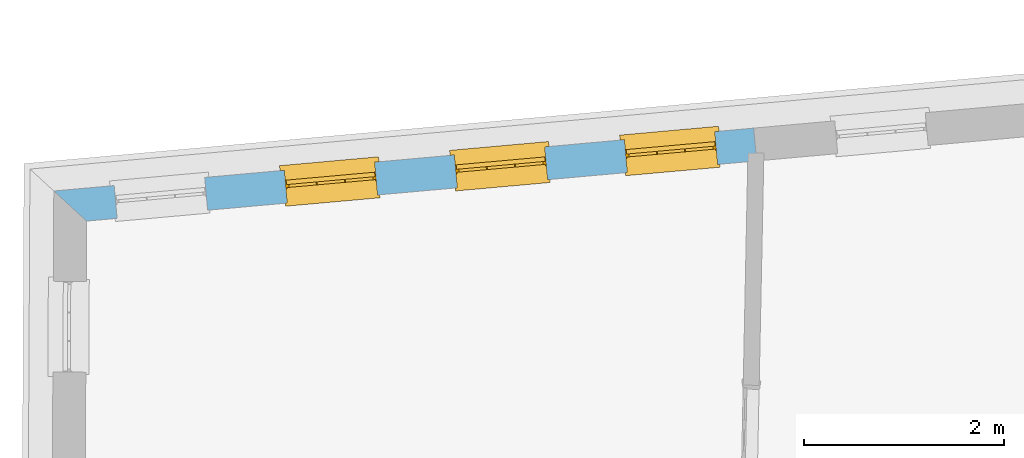
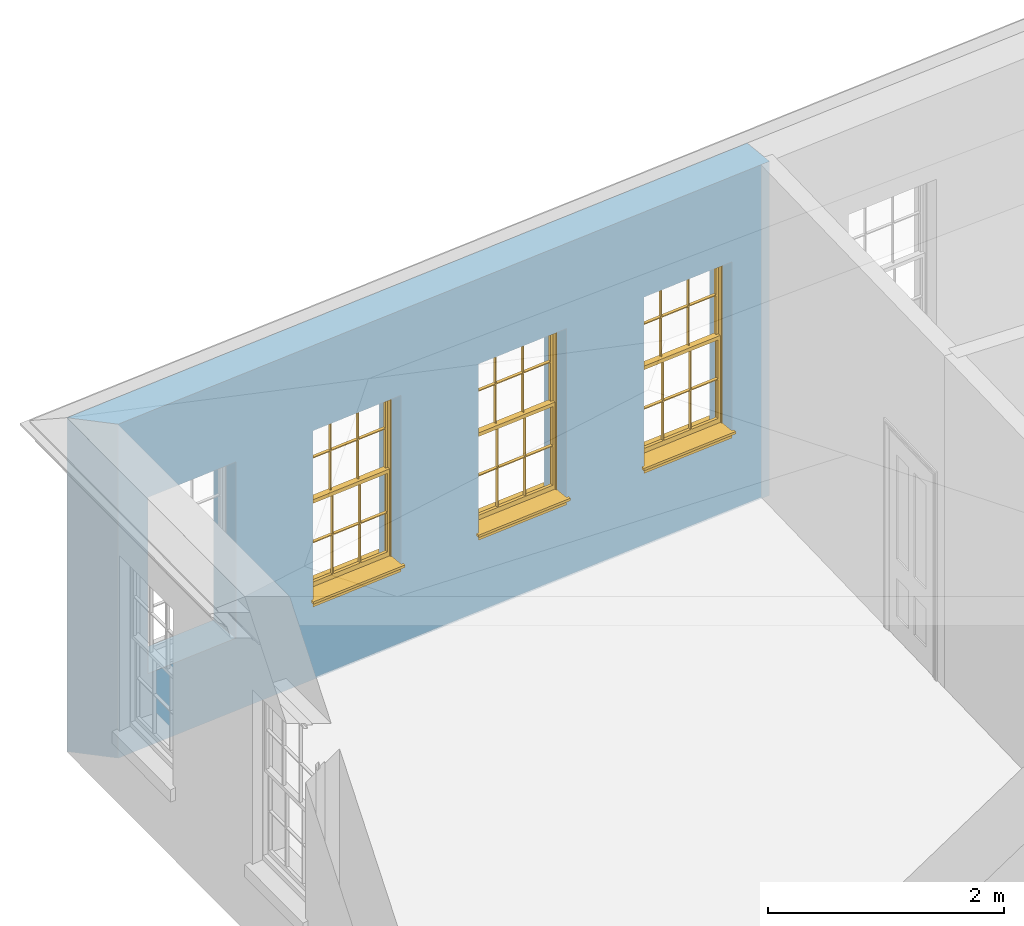
# One storey, part 5 of 14: 3 windows, 4 openings, plus 1 element that does not belong to this part.
"""IFC2X3 building model written with IfcOpenShell, lengths in metres."""

import ifcopenshell
import ifcopenshell.guid

model = None  # the IFC model being written
_history = None  # IfcOwnerHistory: only IFC2X3 demands one
_inside = {}  # id of a spatial element -> (the spatial element, [elements in it])
_under = {}  # id of a project, library or spatial element -> (it, [spatial elements below it])
_declared = {}  # id of a project -> (the project, [libraries it declares])
_typed = {}  # id of a type object -> (the type object, [elements of that type])
_made_of = {}  # id of a material, layer set ... -> (it, [elements and type objects made of it])


def new_model(schema):
    """Start an empty IFC model of exactly this schema.

    Asked for "IFC4X3", IfcOpenShell would pick the latest addendum, in which some entities
    have other attributes; the version numbers below select the first issue.
    IFC2X3 requires an IfcOwnerHistory on every rooted entity: one is made here for all.
    """
    global model, _history
    if schema == "IFC4X3":
        model = ifcopenshell.file(schema_version=(4, 3, 0, 0))
    else:
        model = ifcopenshell.file(schema=schema)
    _inside.clear()
    _under.clear()
    _declared.clear()
    _typed.clear()
    _made_of.clear()
    _history = None
    if model.schema == "IFC2X3":
        org = make("IfcOrganization", Name="unknown")
        user = make(
            "IfcPersonAndOrganization",
            ThePerson=make("IfcPerson", FamilyName="unknown"),
            TheOrganization=org,
        )
        app = make(
            "IfcApplication",
            ApplicationDeveloper=org,
            Version="unknown",
            ApplicationFullName="unknown",
            ApplicationIdentifier="unknown",
        )
        _history = make(
            "IfcOwnerHistory",
            OwningUser=user,
            OwningApplication=app,
            ChangeAction="ADDED",
            CreationDate=0,
        )
    return model


def make(cls, **values):
    """One entity of the class cls with the attributes given. An attribute that is None is left unset."""
    return model.create_entity(
        cls, **{name: value for name, value in values.items() if value is not None}
    )


def rooted(cls, **values):
    """An entity with a GlobalId (a new one), such as an element, a storey or a relation."""
    return make(cls, GlobalId=ifcopenshell.guid.new(), OwnerHistory=_history, **values)


def si_unit(unit_type, name, prefix=None):
    """IfcSIUnit, for example si_unit("LENGTHUNIT", "METRE", prefix="MILLI")."""
    return make("IfcSIUnit", UnitType=unit_type, Prefix=prefix, Name=name)


def assignment(units):
    """IfcUnitAssignment: the units of a project."""
    return None if units is None else make("IfcUnitAssignment", Units=units)


def point(xyz):
    """IfcCartesianPoint."""
    return None if xyz is None else make("IfcCartesianPoint", Coordinates=xyz)


def direction(xyz):
    """IfcDirection."""
    return None if xyz is None else make("IfcDirection", DirectionRatios=xyz)


def frame(location, z_axis=None, x_axis=None):
    """IfcAxis2Placement3D, a coordinate frame: its origin and axes. An axis left out is left unset."""
    return make(
        "IfcAxis2Placement3D",
        Location=point(location),
        Axis=direction(z_axis),
        RefDirection=direction(x_axis),
    )


def origin():
    """The frame at (0, 0, 0) with its axes left unset."""
    return frame((0.0, 0.0, 0.0))


def place(relative_to, where):
    """IfcLocalPlacement: puts the frame where relative to a parent placement (None: the world)."""
    return make(
        "IfcLocalPlacement", PlacementRelTo=relative_to, RelativePlacement=where
    )


def context(
    kind, dimensions, precision=None, world=None, true_north=None, identifier=None
):
    """IfcGeometricRepresentationContext, for example the 3D "Model" context."""
    return make(
        "IfcGeometricRepresentationContext",
        ContextIdentifier=identifier,
        ContextType=kind,
        CoordinateSpaceDimension=dimensions,
        Precision=precision,
        WorldCoordinateSystem=world,
        TrueNorth=true_north,
    )


def subcontext(parent, identifier, kind, view, scale=None):
    """IfcGeometricRepresentationSubContext, for example "Body" below "Model"."""
    return make(
        "IfcGeometricRepresentationSubContext",
        ContextIdentifier=identifier,
        ContextType=kind,
        ParentContext=parent,
        TargetScale=scale,
        TargetView=view,
    )


def project(units=None, contexts=None):
    """IfcProject with its units and contexts."""
    return rooted(
        "IfcProject",
        Name="project",
        RepresentationContexts=contexts,
        UnitsInContext=assignment(units),
    )


def spatial(cls, under=None, at=None, **own):
    """A site, building, storey or space (cls), placed at a placement, below another one or the project."""
    s = rooted(cls, ObjectPlacement=at, **own)
    if under is not None:
        _under.setdefault(under.id(), (under, []))[1].append(s)
    return s


def polyline(points):
    """IfcPolyline through the points."""
    return make("IfcPolyline", Points=[point(p) for p in points])


def outline(outer, holes=None, kind="AREA"):
    """IfcArbitraryClosedProfileDef: a profile drawn as a closed curve; with holes, ...WithVoids."""
    if holes is None:
        return make("IfcArbitraryClosedProfileDef", ProfileType=kind, OuterCurve=outer)
    return make(
        "IfcArbitraryProfileDefWithVoids",
        ProfileType=kind,
        OuterCurve=outer,
        InnerCurves=holes,
    )


def extrude(swept, where, along, depth):
    """IfcExtrudedAreaSolid: the profile swept, set in the frame where, extruded along a direction by depth."""
    return make(
        "IfcExtrudedAreaSolid",
        SweptArea=swept,
        Position=where,
        ExtrudedDirection=direction(along),
        Depth=depth,
    )


def faces_of(points, faces, orient=None, outer=None):
    """IfcFace entities. A face is a list of loops; a loop is a list of indices into points, from 0.

    orient and outer hold one flag for each loop. By default every Orientation is true, the
    first loop of a face is its IfcFaceOuterBound and the others are IfcFaceBound.
    """
    made = []
    for i, loops in enumerate(faces):
        bounds = []
        for j, loop in enumerate(loops):
            is_outer = j == 0 if outer is None else outer[i][j]
            bounds.append(
                make(
                    "IfcFaceOuterBound" if is_outer else "IfcFaceBound",
                    Bound=make("IfcPolyLoop", Polygon=[points[k] for k in loop]),
                    Orientation=True if orient is None else orient[i][j],
                )
            )
        made.append(make("IfcFace", Bounds=bounds))
    return made


def faceted_brep(points, faces, orient=None, outer=None, voids=None):
    """IfcFacetedBrep: a solid bounded by flat faces; with voids (closed shells), ...WithVoids."""
    shared = [point(p) for p in points]
    hull = make("IfcClosedShell", CfsFaces=faces_of(shared, faces, orient, outer))
    if voids is None:
        return make("IfcFacetedBrep", Outer=hull)
    return make(
        "IfcFacetedBrepWithVoids",
        Outer=hull,
        Voids=[
            make(cls, CfsFaces=faces_of(shared, fs, o, b)) for cls, fs, o, b in voids
        ],
    )


def shape(context_of_items, identifier, shape_type, items):
    """IfcShapeRepresentation: the items that make up one representation, for example the "Body"."""
    return make(
        "IfcShapeRepresentation",
        ContextOfItems=context_of_items,
        RepresentationIdentifier=identifier,
        RepresentationType=shape_type,
        Items=items,
    )


def material(Name=None, Category=None):
    """IfcMaterial."""
    return make("IfcMaterial", Name=Name, Category=Category)


def layer(
    of_material, thickness, ventilated=None, Name=None, Category=None, Priority=None
):
    """IfcMaterialLayer: one layer of a wall or slab, of a material (None: an air gap)."""
    return make(
        "IfcMaterialLayer",
        Material=of_material,
        LayerThickness=thickness,
        IsVentilated=ventilated,
        Name=Name,
        Category=Category,
        Priority=Priority,
    )


def layer_set(layers, Name=None):
    """IfcMaterialLayerSet."""
    return make("IfcMaterialLayerSet", MaterialLayers=layers, LayerSetName=Name)


def layer_usage(for_layer_set, set_direction, sense, offset, extent=None):
    """IfcMaterialLayerSetUsage: how a layer set lies in its element."""
    return make(
        "IfcMaterialLayerSetUsage",
        ForLayerSet=for_layer_set,
        LayerSetDirection=set_direction,
        DirectionSense=sense,
        OffsetFromReferenceLine=offset,
        ReferenceExtent=extent,
    )


def made_of(thing, what):
    """Note that an element or type object is made of a material, layer set ...; save() writes the relation."""
    if what is not None:
        _made_of.setdefault(what.id(), (what, []))[1].append(thing)
    return thing


def element(
    cls,
    number,
    at=None,
    inside=None,
    cuts=None,
    type_object=None,
    material=None,
    context=None,
    identifier="Body",
    shape_type=None,
    held_by="IfcProductDefinitionShape",
    body=None,
    shapes=None,
    **own,
):
    """One element of the class cls, such as IfcWall. Its Tag is "e" and its number.

    at: its placement. inside: the storey or other place that contains it. cuts: it is an
    opening in that element (IfcRelVoidsElement). A single representation is given by context,
    identifier, shape_type and body (its items); several are given by shapes. held_by: the class
    of the entity that holds the representations. save() writes the other relations.
    """
    e = rooted(cls, Tag="e%d" % number, ObjectPlacement=at, **own)
    if body is not None:
        shapes = [shape(context, identifier, shape_type, body)]
    if shapes is not None:
        e.Representation = make(held_by, Representations=shapes)
    if inside is not None:
        _inside.setdefault(inside.id(), (inside, []))[1].append(e)
    if cuts is not None:
        rooted(
            "IfcRelVoidsElement", RelatingBuildingElement=cuts, RelatedOpeningElement=e
        )
    if type_object is not None:
        _typed.setdefault(type_object.id(), (type_object, []))[1].append(e)
    return made_of(e, material)


def fill(opening, filler):
    """IfcRelFillsElement: the door or window that sits in an opening."""
    return rooted(
        "IfcRelFillsElement",
        RelatingOpeningElement=opening,
        RelatedBuildingElement=filler,
    )


def aggregate(whole, parts):
    """IfcRelAggregates: a whole, such as a stair, and the parts it consists of."""
    return rooted("IfcRelAggregates", RelatingObject=whole, RelatedObjects=parts)


def save(model, path):
    """Write the relations noted so far, then the file.

    IfcRelAggregates (storeys below a building ...), IfcRelContainedInSpatialStructure (elements
    in a storey), IfcRelDefinesByType, IfcRelAssociatesMaterial and IfcRelDeclares: one each for
    every whole, place, type object, material and project.
    """
    for whole, parts in _under.values():
        aggregate(whole, parts)
    for where, things in _inside.values():
        rooted(
            "IfcRelContainedInSpatialStructure",
            RelatedElements=things,
            RelatingStructure=where,
        )
    for kind, things in _typed.values():
        rooted("IfcRelDefinesByType", RelatedObjects=things, RelatingType=kind)
    for what, things in _made_of.values():
        rooted("IfcRelAssociatesMaterial", RelatedObjects=things, RelatingMaterial=what)
    for by, libraries in _declared.values():
        rooted("IfcRelDeclares", RelatingContext=by, RelatedDefinitions=libraries)
    model.write(path)


model = new_model("IFC2X3")

# Units and contexts
model_context = context("Model", 3, world=origin())
body_context = subcontext(model_context, "Body", "Model", "MODEL_VIEW")
ifc_project = project(units=[si_unit("PLANEANGLEUNIT", "RADIAN"), si_unit("MASSUNIT", "GRAM", prefix="KILO"), si_unit("FORCEUNIT", "NEWTON", prefix="KILO"), si_unit("LENGTHUNIT", "METRE")], contexts=[model_context])

# Site, building, storey
site_placement = place(None, origin())
site = spatial("IfcSite", under=ifc_project, at=site_placement, CompositionType="ELEMENT")
building_placement = place(None, origin())
building = spatial("IfcBuilding", under=site, at=building_placement, Name="Building plot-17", CompositionType="ELEMENT")
storey_placement = place(None, frame((0.0, 0.0, 6.15)))
storey = spatial("IfcBuildingStorey", under=building, at=storey_placement, Name="Floor 1", CompositionType="ELEMENT", Elevation=6.15)

# Wall, openings, windows
ifc_material = material(Name="Masonry")
ifc_layer = layer(ifc_material, 0.33, ventilated=False)
ifc_layer_set = layer_set([ifc_layer], Name="My Wall")
ifc_layer_usage = layer_usage(ifc_layer_set, "AXIS2", "NEGATIVE", 0.08)
wall_placement = place(storey_placement, origin())
wall = element("IfcWallStandardCase", 1, at=wall_placement, inside=storey, material=ifc_layer_usage, Name="exterior", context=body_context, shape_type="SweptSolid", body=[
    extrude(outline(polyline([(77.4514973462638, 26.0607374425634), (77.4219746484992, 26.3894141991445), (70.4115738095909, 25.7597197013384), (70.7400454135505, 25.4578954009408), (77.4514973462638, 26.0607374425634)])), origin(), (0.0, 0.0, 1.0), 3.45),
])
opening_1_placement = place(storey_placement, frame((0.0, 0.0, 0.75)))
opening_1 = element("IfcOpeningElement", 2, at=opening_1_placement, cuts=wall, Name="Opening", ObjectType="Opening", context=body_context, shape_type="SweptSolid", body=[
    extrude(outline(polyline([(77.0323071544384, 26.354413136777), (76.1259560984116, 26.273002061123), (76.1554787961762, 25.9443253045419), (77.061829852203, 26.0257363801958), (77.0323071544384, 26.354413136777)])), origin(), (0.0, 0.0, 1.0), 1.82),
])
opening_2_placement = place(storey_placement, frame((0.0, 0.0, 0.75)))
opening_2 = element("IfcOpeningElement", 3, at=opening_2_placement, cuts=wall, Name="Opening", ObjectType="Opening", context=body_context, shape_type="SweptSolid", body=[
    extrude(outline(polyline([(75.3291639612452, 26.201431884724), (74.4228129052184, 26.12002080907), (74.452335602983, 25.7913440524889), (75.3586866590098, 25.8727551281428), (75.3291639612452, 26.201431884724)])), origin(), (0.0, 0.0, 1.0), 1.82),
])
opening_3_placement = place(storey_placement, frame((0.0, 0.0, 0.75)))
opening_3 = element("IfcOpeningElement", 4, at=opening_3_placement, cuts=wall, Name="Opening", ObjectType="Opening", context=body_context, shape_type="SweptSolid", body=[
    extrude(outline(polyline([(73.626020768052, 26.0484506326709), (72.7196697120252, 25.967039557017), (72.7491924097898, 25.6383628004358), (73.6555434658166, 25.7197738760898), (73.626020768052, 26.0484506326709)])), origin(), (0.0, 0.0, 1.0), 1.82),
])
opening_4_placement = place(storey_placement, frame((0.0, 0.0, 0.75)))
element("IfcOpeningElement", 5, at=opening_4_placement, cuts=wall, Name="Opening", ObjectType="Opening", context=body_context, shape_type="SweptSolid", body=[
    extrude(outline(polyline([(71.9228775748588, 25.8954693806179), (71.016526518832, 25.814058304964), (71.0460492165967, 25.4853815483828), (71.9524002726234, 25.5667926240368), (71.9228775748588, 25.8954693806179)])), origin(), (0.0, 0.0, 1.0), 1.82),
])
window_1_placement = place(storey_placement, frame((77.0546728345631, 26.1054155939125, 0.75), z_axis=(0.0, 0.0, 1.0), x_axis=(-0.906351056026793, -0.0814110756539463, 0.0)))
window_1 = element("IfcWindow", 6, at=window_1_placement, inside=storey, Name="bedroom outside window", OverallHeight=1.82, OverallWidth=0.91, context=body_context, shape_type="Brep", held_by="IfcProductRepresentation", body=[
    faceted_brep([(0.033125, -0.105, 0.975209), (0.01, -0.105, 0.975209), (0.033125, -0.105, 1.376042), (0.876875, -0.105, 0.975209), (0.876875, -0.105, 1.376042), (0.9, -0.105, 0.975209), (0.876875, -0.105, 1.386042), (0.876875, -0.105, 1.786875), (0.9, -0.105, 1.81), (0.033125, -0.105, 1.786875), (0.033125, -0.105, 1.386042), (0.01, -0.105, 1.81), (0.876875, -0.135, 1.376042), (0.876875, -0.135, 0.975209), (0.9, -0.135, 0.937083), (0.033125, -0.135, 1.786875), (0.01, -0.135, 1.81), (0.033125, -0.135, 1.386042), (0.01, -0.135, 0.937083), (0.033125, -0.135, 0.975209), (0.033125, -0.135, 1.376042), (0.876875, -0.135, 1.786875), (0.876875, -0.135, 1.386042), (0.9, -0.135, 1.81), (0.033125, -0.105, 0.937083), (0.01, -0.105, 0.937083), (0.033125, -0.105, 0.53625), (0.876875, -0.105, 0.937083), (0.876875, -0.105, 0.53625), (0.9, -0.105, 0.937083), (0.876875, -0.105, 0.52625), (0.876875, -0.105, 0.125417), (0.9, -0.105, 0.077167), (0.033125, -0.105, 0.125417), (0.033125, -0.105, 0.52625), (0.01, -0.105, 0.077167), (-0.0425, -0.25, 0.01), (-0.0425, -0.3, 0.001667), (0.0, -0.25, 0.01), (0.9525, -0.25, 0.01), (0.91, -0.25, 0.01), (0.9525, -0.3, 0.001667), (-0.02, 0.08, 0.077167), (0.0, 0.08, 0.077167), (-0.02, 0.11, 0.077167), (0.0, -0.06, 0.077167), (0.01, -0.06, 0.077167), (0.91, -0.06, 0.077167), (0.91, 0.08, 0.077167), (0.9, -0.06, 0.077167), (0.93, 0.08, 0.077167), (0.93, 0.11, 0.077167), (0.01, -0.075, 0.975209), (0.9, -0.075, 0.975209), (0.876875, -0.075, 0.125417), (0.876875, -0.075, 0.52625), (0.9, -0.075, 0.077167), (0.876875, -0.075, 0.53625), (0.876875, -0.075, 0.937083), (0.033125, -0.075, 0.125417), (0.01, -0.075, 0.077167), (0.033125, -0.075, 0.52625), (0.033125, -0.075, 0.937083), (0.033125, -0.075, 0.53625), (-0.02, 0.08, 0.052167), (-0.02, 0.11, 0.052167), (0.93, 0.11, 0.052167), (0.93, 0.08, 0.052167), (0.91, 0.08, 0.052167), (0.0, 0.08, 0.052167), (0.91, -0.15, 0.026667), (0.0, -0.15, 0.026667), (-0.0425, -0.3, -0.123333), (0.9525, -0.3, -0.123333), (-0.0425, -0.25, -0.123333), (0.9525, -0.25, -0.123333), (0.01, -0.06, 1.81), (0.9, -0.06, 1.81), (0.0, -0.06, 1.82), (0.91, -0.06, 1.82), (0.01, -0.15, 0.077167), (0.9, -0.15, 0.077167), (0.592292, -0.105, 0.125417), (0.592292, -0.075, 0.125417), (0.317708, -0.075, 0.125417), (0.317708, -0.105, 0.125417), (0.592292, -0.105, 0.53625), (0.317708, -0.105, 0.53625), (0.317708, -0.105, 0.52625), (0.592292, -0.105, 0.52625), (0.592292, -0.075, 0.53625), (0.317708, -0.075, 0.53625), (0.592292, -0.135, 1.386042), (0.592292, -0.105, 1.386042), (0.317708, -0.105, 1.386042), (0.317708, -0.135, 1.386042), (0.317708, -0.135, 1.376042), (0.592292, -0.135, 1.376042), (0.317708, -0.105, 1.376042), (0.592292, -0.105, 1.376042), (0.602292, -0.135, 1.376042), (0.592292, -0.135, 0.975209), (0.602292, -0.135, 0.975209), (0.602292, -0.105, 0.975209), (0.592292, -0.105, 0.975209), (0.602292, -0.105, 1.376042), (0.602292, -0.075, 0.53625), (0.602292, -0.105, 0.53625), (0.317708, -0.075, 0.52625), (0.307708, -0.075, 0.125417), (0.307708, -0.075, 0.52625), (0.602292, -0.075, 0.52625), (0.602292, -0.075, 0.125417), (0.592292, -0.075, 0.52625), (0.307708, -0.075, 0.53625), (0.317708, -0.075, 0.937083), (0.307708, -0.075, 0.937083), (0.602292, -0.075, 0.937083), (0.592292, -0.075, 0.937083), (0.307708, -0.105, 0.52625), (0.307708, -0.105, 0.125417), (0.307708, -0.105, 0.53625), (0.307708, -0.105, 0.937083), (0.592292, -0.105, 0.937083), (0.317708, -0.105, 0.937083), (0.602292, -0.105, 0.937083), (0.602292, -0.105, 0.52625), (0.602292, -0.105, 0.125417), (0.307708, -0.135, 1.386042), (0.307708, -0.135, 1.376042), (0.307708, -0.135, 0.975209), (0.317708, -0.135, 0.975209), (0.317708, -0.135, 1.786875), (0.307708, -0.135, 1.786875), (0.602292, -0.135, 1.786875), (0.592292, -0.135, 1.786875), (0.602292, -0.135, 1.386042), (0.602292, -0.105, 1.386042), (0.307708, -0.105, 1.386042), (0.307708, -0.105, 1.786875), (0.317708, -0.105, 1.786875), (0.592292, -0.105, 1.786875), (0.602292, -0.105, 1.786875), (0.307708, -0.105, 1.376042), (0.317708, -0.105, 0.975209), (0.307708, -0.105, 0.975209), (0.91, -0.15, 1.82), (0.9, -0.15, 1.81), (0.01, -0.15, 1.81), (0.0, -0.15, 1.82), (0.91, -0.25, 0.0), (0.0, -0.25, 0.0), (0.91, 0.08, 0.0), (0.0, 0.08, 0.0)], [[[0, 1, 2]], [[3, 4, 5]], [[6, 7, 8]], [[9, 10, 11]], [[12, 13, 14]], [[15, 16, 17]], [[18, 19, 20]], [[21, 22, 23]], [[24, 25, 26]], [[27, 28, 29]], [[30, 31, 32]], [[33, 34, 35]], [[14, 27, 29]], [[25, 24, 18]], [[36, 37, 38]], [[39, 40, 41]], [[42, 43, 44]], [[45, 46, 43]], [[47, 48, 49]], [[50, 51, 48]], [[1, 0, 52]], [[5, 53, 3]], [[54, 55, 56]], [[57, 58, 53]], [[59, 60, 61]], [[62, 63, 52]], [[48, 43, 46, 49]], [[51, 44, 43, 48]], [[64, 42, 44, 65]], [[65, 44, 51, 66]], [[66, 51, 50, 67]], [[65, 66, 68, 69]], [[60, 56, 49, 46]], [[70, 71, 38, 40]], [[37, 41, 40, 38]], [[37, 72, 73, 41]], [[74, 75, 73, 72]], [[8, 11, 76, 77]], [[76, 78, 79, 77]], [[32, 35, 80, 81]], [[81, 80, 71, 70]], [[82, 83, 84, 85]], [[86, 87, 88, 89]], [[86, 90, 91, 87]], [[92, 93, 94, 95]], [[92, 95, 96, 97]], [[96, 98, 99, 97]], [[100, 97, 101, 102]], [[103, 104, 99, 105]], [[97, 99, 104, 101]], [[102, 103, 105, 100]], [[28, 57, 106, 107]], [[108, 84, 109, 110]], [[111, 112, 83, 113]], [[114, 110, 61, 63]], [[90, 113, 108, 91]], [[115, 91, 114, 116]], [[117, 106, 90, 118]], [[111, 106, 57, 55]], [[119, 110, 109, 120]], [[34, 61, 110, 119]], [[89, 113, 83, 82]], [[88, 108, 113, 89]], [[85, 84, 108, 88]], [[121, 114, 63, 26]], [[122, 116, 114, 121]], [[123, 118, 90, 86]], [[87, 91, 115, 124]], [[107, 106, 117, 125]], [[126, 111, 55, 30]], [[127, 112, 111, 126]], [[126, 30, 28, 107]], [[88, 119, 120, 85]], [[126, 89, 82, 127]], [[125, 123, 86, 107]], [[121, 26, 34, 119]], [[124, 122, 121, 87]], [[128, 17, 20, 129]], [[96, 129, 130, 131]], [[132, 133, 128, 95]], [[134, 135, 92, 136]], [[100, 12, 22, 136]], [[137, 6, 4, 105]], [[94, 138, 139, 140]], [[137, 93, 141, 142]], [[99, 98, 94, 93]], [[143, 2, 10, 138]], [[144, 145, 143, 98]], [[129, 143, 145, 130]], [[20, 2, 143, 129]], [[131, 144, 98, 96]], [[128, 138, 10, 17]], [[133, 139, 138, 128]], [[135, 141, 93, 92]], [[95, 94, 140, 132]], [[22, 6, 137, 136]], [[136, 137, 142, 134]], [[100, 105, 4, 12]], [[107, 86, 89, 126]], [[106, 111, 113, 90]], [[91, 108, 110, 114]], [[87, 121, 119, 88]], [[97, 100, 136, 92]], [[129, 96, 95, 128]], [[98, 143, 138, 94]], [[105, 99, 93, 137]], [[131, 101, 104, 144]], [[124, 115, 118, 123]], [[132, 140, 141, 135]], [[120, 109, 59, 33]], [[15, 9, 139, 133]], [[134, 142, 7, 21]], [[31, 54, 112, 127]], [[36, 74, 72, 37]], [[39, 41, 73, 75]], [[18, 14, 101, 131]], [[23, 16, 132, 135]], [[83, 56, 60, 84]], [[52, 53, 118, 115]], [[53, 52, 144, 104]], [[11, 8, 141, 140]], [[14, 18, 124, 123]], [[2, 1, 11, 10]], [[8, 5, 4, 6]], [[57, 53, 56, 55]], [[60, 52, 63, 61]], [[26, 25, 35, 34]], [[32, 29, 28, 30]], [[14, 23, 22, 12]], [[18, 20, 17, 16]], [[19, 0, 2, 20]], [[17, 10, 9, 15]], [[12, 4, 3, 13]], [[21, 7, 6, 22]], [[27, 58, 57, 28]], [[30, 55, 54, 31]], [[33, 59, 61, 34]], [[26, 63, 62, 24]], [[5, 8, 77, 53]], [[76, 11, 1, 52]], [[46, 45, 78, 76]], [[49, 77, 79, 47]], [[70, 146, 147, 81]], [[71, 80, 148, 149]], [[19, 130, 145, 0]], [[102, 13, 3, 103]], [[116, 122, 24, 62]], [[29, 32, 81, 14]], [[80, 35, 25, 18]], [[60, 46, 76, 52]], [[77, 49, 56, 53]], [[23, 14, 81, 147]], [[16, 148, 80, 18]], [[35, 85, 120]], [[120, 33, 35]], [[127, 82, 32]], [[32, 31, 127]], [[32, 82, 85, 35]], [[102, 101, 14]], [[14, 13, 102]], [[18, 131, 130]], [[130, 19, 18]], [[134, 21, 23]], [[23, 135, 134]], [[16, 15, 133]], [[133, 132, 16]], [[11, 140, 139]], [[139, 9, 11]], [[142, 141, 8]], [[8, 7, 142]], [[23, 147, 148, 16]], [[146, 149, 148, 147]], [[52, 115, 116]], [[116, 62, 52]], [[118, 53, 117]], [[58, 117, 53]], [[27, 125, 117, 58]], [[56, 83, 112]], [[112, 54, 56]], [[109, 84, 60]], [[60, 59, 109]], [[125, 27, 14]], [[14, 123, 125]], [[122, 124, 18]], [[18, 24, 122]], [[145, 144, 52]], [[52, 0, 145]], [[103, 3, 53]], [[53, 104, 103]], [[79, 78, 149, 146]], [[78, 45, 71, 149]], [[146, 70, 47, 79]], [[150, 75, 74, 151]], [[68, 66, 67]], [[48, 68, 67, 50]], [[69, 64, 65]], [[42, 64, 69, 43]], [[69, 68, 152, 153]], [[70, 68, 48, 47]], [[150, 152, 68, 70]], [[43, 69, 71, 45]], [[69, 153, 151, 71]], [[152, 150, 151, 153]], [[38, 151, 74, 36]], [[71, 151, 38]], [[39, 75, 150, 40]], [[40, 150, 70]]]),
])
fill(opening_1, window_1)
window_2_placement = place(storey_placement, frame((75.3515296413699, 25.9524343418595, 0.75), z_axis=(0.0, 0.0, 1.0), x_axis=(-0.906351056026779, -0.0814110756539499, 0.0)))
window_2 = element("IfcWindow", 7, at=window_2_placement, inside=storey, Name="bedroom outside window", OverallHeight=1.82, OverallWidth=0.91, context=body_context, shape_type="Brep", held_by="IfcProductRepresentation", body=[
    faceted_brep([(0.033125, -0.105, 0.975209), (0.01, -0.105, 0.975209), (0.033125, -0.105, 1.376042), (0.876875, -0.105, 0.975209), (0.876875, -0.105, 1.376042), (0.9, -0.105, 0.975209), (0.876875, -0.105, 1.386042), (0.876875, -0.105, 1.786875), (0.9, -0.105, 1.81), (0.033125, -0.105, 1.786875), (0.033125, -0.105, 1.386042), (0.01, -0.105, 1.81), (0.876875, -0.135, 1.376042), (0.876875, -0.135, 0.975209), (0.9, -0.135, 0.937083), (0.033125, -0.135, 1.786875), (0.01, -0.135, 1.81), (0.033125, -0.135, 1.386042), (0.01, -0.135, 0.937083), (0.033125, -0.135, 0.975209), (0.033125, -0.135, 1.376042), (0.876875, -0.135, 1.786875), (0.876875, -0.135, 1.386042), (0.9, -0.135, 1.81), (0.033125, -0.105, 0.937083), (0.01, -0.105, 0.937083), (0.033125, -0.105, 0.53625), (0.876875, -0.105, 0.937083), (0.876875, -0.105, 0.53625), (0.9, -0.105, 0.937083), (0.876875, -0.105, 0.52625), (0.876875, -0.105, 0.125417), (0.9, -0.105, 0.077167), (0.033125, -0.105, 0.125417), (0.033125, -0.105, 0.52625), (0.01, -0.105, 0.077167), (-0.0425, -0.25, 0.01), (-0.0425, -0.3, 0.001667), (0.0, -0.25, 0.01), (0.9525, -0.25, 0.01), (0.91, -0.25, 0.01), (0.9525, -0.3, 0.001667), (-0.02, 0.08, 0.077167), (0.0, 0.08, 0.077167), (-0.02, 0.11, 0.077167), (0.0, -0.06, 0.077167), (0.01, -0.06, 0.077167), (0.91, -0.06, 0.077167), (0.91, 0.08, 0.077167), (0.9, -0.06, 0.077167), (0.93, 0.08, 0.077167), (0.93, 0.11, 0.077167), (0.01, -0.075, 0.975209), (0.9, -0.075, 0.975209), (0.876875, -0.075, 0.125417), (0.876875, -0.075, 0.52625), (0.9, -0.075, 0.077167), (0.876875, -0.075, 0.53625), (0.876875, -0.075, 0.937083), (0.033125, -0.075, 0.125417), (0.01, -0.075, 0.077167), (0.033125, -0.075, 0.52625), (0.033125, -0.075, 0.937083), (0.033125, -0.075, 0.53625), (-0.02, 0.08, 0.052167), (-0.02, 0.11, 0.052167), (0.93, 0.11, 0.052167), (0.93, 0.08, 0.052167), (0.91, 0.08, 0.052167), (0.0, 0.08, 0.052167), (0.91, -0.15, 0.026667), (0.0, -0.15, 0.026667), (-0.0425, -0.3, -0.123333), (0.9525, -0.3, -0.123333), (-0.0425, -0.25, -0.123333), (0.9525, -0.25, -0.123333), (0.01, -0.06, 1.81), (0.9, -0.06, 1.81), (0.0, -0.06, 1.82), (0.91, -0.06, 1.82), (0.01, -0.15, 0.077167), (0.9, -0.15, 0.077167), (0.592292, -0.105, 0.125417), (0.592292, -0.075, 0.125417), (0.317708, -0.075, 0.125417), (0.317708, -0.105, 0.125417), (0.592292, -0.105, 0.53625), (0.317708, -0.105, 0.53625), (0.317708, -0.105, 0.52625), (0.592292, -0.105, 0.52625), (0.592292, -0.075, 0.53625), (0.317708, -0.075, 0.53625), (0.592292, -0.135, 1.386042), (0.592292, -0.105, 1.386042), (0.317708, -0.105, 1.386042), (0.317708, -0.135, 1.386042), (0.317708, -0.135, 1.376042), (0.592292, -0.135, 1.376042), (0.317708, -0.105, 1.376042), (0.592292, -0.105, 1.376042), (0.602292, -0.135, 1.376042), (0.592292, -0.135, 0.975209), (0.602292, -0.135, 0.975209), (0.602292, -0.105, 0.975209), (0.592292, -0.105, 0.975209), (0.602292, -0.105, 1.376042), (0.602292, -0.075, 0.53625), (0.602292, -0.105, 0.53625), (0.317708, -0.075, 0.52625), (0.307708, -0.075, 0.125417), (0.307708, -0.075, 0.52625), (0.602292, -0.075, 0.52625), (0.602292, -0.075, 0.125417), (0.592292, -0.075, 0.52625), (0.307708, -0.075, 0.53625), (0.317708, -0.075, 0.937083), (0.307708, -0.075, 0.937083), (0.602292, -0.075, 0.937083), (0.592292, -0.075, 0.937083), (0.307708, -0.105, 0.52625), (0.307708, -0.105, 0.125417), (0.307708, -0.105, 0.53625), (0.307708, -0.105, 0.937083), (0.592292, -0.105, 0.937083), (0.317708, -0.105, 0.937083), (0.602292, -0.105, 0.937083), (0.602292, -0.105, 0.52625), (0.602292, -0.105, 0.125417), (0.307708, -0.135, 1.386042), (0.307708, -0.135, 1.376042), (0.307708, -0.135, 0.975209), (0.317708, -0.135, 0.975209), (0.317708, -0.135, 1.786875), (0.307708, -0.135, 1.786875), (0.602292, -0.135, 1.786875), (0.592292, -0.135, 1.786875), (0.602292, -0.135, 1.386042), (0.602292, -0.105, 1.386042), (0.307708, -0.105, 1.386042), (0.307708, -0.105, 1.786875), (0.317708, -0.105, 1.786875), (0.592292, -0.105, 1.786875), (0.602292, -0.105, 1.786875), (0.307708, -0.105, 1.376042), (0.317708, -0.105, 0.975209), (0.307708, -0.105, 0.975209), (0.91, -0.15, 1.82), (0.9, -0.15, 1.81), (0.01, -0.15, 1.81), (0.0, -0.15, 1.82), (0.91, -0.25, 0.0), (0.0, -0.25, 0.0), (0.91, 0.08, 0.0), (0.0, 0.08, 0.0)], [[[0, 1, 2]], [[3, 4, 5]], [[6, 7, 8]], [[9, 10, 11]], [[12, 13, 14]], [[15, 16, 17]], [[18, 19, 20]], [[21, 22, 23]], [[24, 25, 26]], [[27, 28, 29]], [[30, 31, 32]], [[33, 34, 35]], [[14, 27, 29]], [[25, 24, 18]], [[36, 37, 38]], [[39, 40, 41]], [[42, 43, 44]], [[45, 46, 43]], [[47, 48, 49]], [[50, 51, 48]], [[1, 0, 52]], [[5, 53, 3]], [[54, 55, 56]], [[57, 58, 53]], [[59, 60, 61]], [[62, 63, 52]], [[48, 43, 46, 49]], [[51, 44, 43, 48]], [[64, 42, 44, 65]], [[65, 44, 51, 66]], [[66, 51, 50, 67]], [[65, 66, 68, 69]], [[60, 56, 49, 46]], [[70, 71, 38, 40]], [[37, 41, 40, 38]], [[37, 72, 73, 41]], [[74, 75, 73, 72]], [[8, 11, 76, 77]], [[76, 78, 79, 77]], [[32, 35, 80, 81]], [[81, 80, 71, 70]], [[82, 83, 84, 85]], [[86, 87, 88, 89]], [[86, 90, 91, 87]], [[92, 93, 94, 95]], [[92, 95, 96, 97]], [[96, 98, 99, 97]], [[100, 97, 101, 102]], [[103, 104, 99, 105]], [[97, 99, 104, 101]], [[102, 103, 105, 100]], [[28, 57, 106, 107]], [[108, 84, 109, 110]], [[111, 112, 83, 113]], [[114, 110, 61, 63]], [[90, 113, 108, 91]], [[115, 91, 114, 116]], [[117, 106, 90, 118]], [[111, 106, 57, 55]], [[119, 110, 109, 120]], [[34, 61, 110, 119]], [[89, 113, 83, 82]], [[88, 108, 113, 89]], [[85, 84, 108, 88]], [[121, 114, 63, 26]], [[122, 116, 114, 121]], [[123, 118, 90, 86]], [[87, 91, 115, 124]], [[107, 106, 117, 125]], [[126, 111, 55, 30]], [[127, 112, 111, 126]], [[126, 30, 28, 107]], [[88, 119, 120, 85]], [[126, 89, 82, 127]], [[125, 123, 86, 107]], [[121, 26, 34, 119]], [[124, 122, 121, 87]], [[128, 17, 20, 129]], [[96, 129, 130, 131]], [[132, 133, 128, 95]], [[134, 135, 92, 136]], [[100, 12, 22, 136]], [[137, 6, 4, 105]], [[94, 138, 139, 140]], [[137, 93, 141, 142]], [[99, 98, 94, 93]], [[143, 2, 10, 138]], [[144, 145, 143, 98]], [[129, 143, 145, 130]], [[20, 2, 143, 129]], [[131, 144, 98, 96]], [[128, 138, 10, 17]], [[133, 139, 138, 128]], [[135, 141, 93, 92]], [[95, 94, 140, 132]], [[22, 6, 137, 136]], [[136, 137, 142, 134]], [[100, 105, 4, 12]], [[107, 86, 89, 126]], [[106, 111, 113, 90]], [[91, 108, 110, 114]], [[87, 121, 119, 88]], [[97, 100, 136, 92]], [[129, 96, 95, 128]], [[98, 143, 138, 94]], [[105, 99, 93, 137]], [[131, 101, 104, 144]], [[124, 115, 118, 123]], [[132, 140, 141, 135]], [[120, 109, 59, 33]], [[15, 9, 139, 133]], [[134, 142, 7, 21]], [[31, 54, 112, 127]], [[36, 74, 72, 37]], [[39, 41, 73, 75]], [[18, 14, 101, 131]], [[23, 16, 132, 135]], [[83, 56, 60, 84]], [[52, 53, 118, 115]], [[53, 52, 144, 104]], [[11, 8, 141, 140]], [[14, 18, 124, 123]], [[2, 1, 11, 10]], [[8, 5, 4, 6]], [[57, 53, 56, 55]], [[60, 52, 63, 61]], [[26, 25, 35, 34]], [[32, 29, 28, 30]], [[14, 23, 22, 12]], [[18, 20, 17, 16]], [[19, 0, 2, 20]], [[17, 10, 9, 15]], [[12, 4, 3, 13]], [[21, 7, 6, 22]], [[27, 58, 57, 28]], [[30, 55, 54, 31]], [[33, 59, 61, 34]], [[26, 63, 62, 24]], [[5, 8, 77, 53]], [[76, 11, 1, 52]], [[46, 45, 78, 76]], [[49, 77, 79, 47]], [[70, 146, 147, 81]], [[71, 80, 148, 149]], [[19, 130, 145, 0]], [[102, 13, 3, 103]], [[116, 122, 24, 62]], [[29, 32, 81, 14]], [[80, 35, 25, 18]], [[60, 46, 76, 52]], [[77, 49, 56, 53]], [[23, 14, 81, 147]], [[16, 148, 80, 18]], [[35, 85, 120]], [[120, 33, 35]], [[127, 82, 32]], [[32, 31, 127]], [[32, 82, 85, 35]], [[102, 101, 14]], [[14, 13, 102]], [[18, 131, 130]], [[130, 19, 18]], [[134, 21, 23]], [[23, 135, 134]], [[16, 15, 133]], [[133, 132, 16]], [[11, 140, 139]], [[139, 9, 11]], [[142, 141, 8]], [[8, 7, 142]], [[23, 147, 148, 16]], [[146, 149, 148, 147]], [[52, 115, 116]], [[116, 62, 52]], [[118, 53, 117]], [[58, 117, 53]], [[27, 125, 117, 58]], [[56, 83, 112]], [[112, 54, 56]], [[109, 84, 60]], [[60, 59, 109]], [[125, 27, 14]], [[14, 123, 125]], [[122, 124, 18]], [[18, 24, 122]], [[145, 144, 52]], [[52, 0, 145]], [[103, 3, 53]], [[53, 104, 103]], [[79, 78, 149, 146]], [[78, 45, 71, 149]], [[146, 70, 47, 79]], [[150, 75, 74, 151]], [[68, 66, 67]], [[48, 68, 67, 50]], [[69, 64, 65]], [[42, 64, 69, 43]], [[69, 68, 152, 153]], [[70, 68, 48, 47]], [[150, 152, 68, 70]], [[43, 69, 71, 45]], [[69, 153, 151, 71]], [[152, 150, 151, 153]], [[38, 151, 74, 36]], [[71, 151, 38]], [[39, 75, 150, 40]], [[40, 150, 70]]]),
])
fill(opening_2, window_2)
window_3_placement = place(storey_placement, frame((73.6483864481767, 25.7994530898064, 0.75), z_axis=(0.0, 0.0, 1.0), x_axis=(-0.906351056026779, -0.0814110756539463, 0.0)))
window_3 = element("IfcWindow", 8, at=window_3_placement, inside=storey, Name="bedroom outside window", OverallHeight=1.82, OverallWidth=0.91, context=body_context, shape_type="Brep", held_by="IfcProductRepresentation", body=[
    faceted_brep([(0.033125, -0.105, 0.975209), (0.01, -0.105, 0.975209), (0.033125, -0.105, 1.376042), (0.876875, -0.105, 0.975209), (0.876875, -0.105, 1.376042), (0.9, -0.105, 0.975209), (0.876875, -0.105, 1.386042), (0.876875, -0.105, 1.786875), (0.9, -0.105, 1.81), (0.033125, -0.105, 1.786875), (0.033125, -0.105, 1.386042), (0.01, -0.105, 1.81), (0.876875, -0.135, 1.376042), (0.876875, -0.135, 0.975209), (0.9, -0.135, 0.937083), (0.033125, -0.135, 1.786875), (0.01, -0.135, 1.81), (0.033125, -0.135, 1.386042), (0.01, -0.135, 0.937083), (0.033125, -0.135, 0.975209), (0.033125, -0.135, 1.376042), (0.876875, -0.135, 1.786875), (0.876875, -0.135, 1.386042), (0.9, -0.135, 1.81), (0.033125, -0.105, 0.937083), (0.01, -0.105, 0.937083), (0.033125, -0.105, 0.53625), (0.876875, -0.105, 0.937083), (0.876875, -0.105, 0.53625), (0.9, -0.105, 0.937083), (0.876875, -0.105, 0.52625), (0.876875, -0.105, 0.125417), (0.9, -0.105, 0.077167), (0.033125, -0.105, 0.125417), (0.033125, -0.105, 0.52625), (0.01, -0.105, 0.077167), (-0.0425, -0.25, 0.01), (-0.0425, -0.3, 0.001667), (0.0, -0.25, 0.01), (0.9525, -0.25, 0.01), (0.91, -0.25, 0.01), (0.9525, -0.3, 0.001667), (-0.02, 0.08, 0.077167), (0.0, 0.08, 0.077167), (-0.02, 0.11, 0.077167), (0.0, -0.06, 0.077167), (0.01, -0.06, 0.077167), (0.91, -0.06, 0.077167), (0.91, 0.08, 0.077167), (0.9, -0.06, 0.077167), (0.93, 0.08, 0.077167), (0.93, 0.11, 0.077167), (0.01, -0.075, 0.975209), (0.9, -0.075, 0.975209), (0.876875, -0.075, 0.125417), (0.876875, -0.075, 0.52625), (0.9, -0.075, 0.077167), (0.876875, -0.075, 0.53625), (0.876875, -0.075, 0.937083), (0.033125, -0.075, 0.125417), (0.01, -0.075, 0.077167), (0.033125, -0.075, 0.52625), (0.033125, -0.075, 0.937083), (0.033125, -0.075, 0.53625), (-0.02, 0.08, 0.052167), (-0.02, 0.11, 0.052167), (0.93, 0.11, 0.052167), (0.93, 0.08, 0.052167), (0.91, 0.08, 0.052167), (0.0, 0.08, 0.052167), (0.91, -0.15, 0.026667), (0.0, -0.15, 0.026667), (-0.0425, -0.3, -0.123333), (0.9525, -0.3, -0.123333), (-0.0425, -0.25, -0.123333), (0.9525, -0.25, -0.123333), (0.01, -0.06, 1.81), (0.9, -0.06, 1.81), (0.0, -0.06, 1.82), (0.91, -0.06, 1.82), (0.01, -0.15, 0.077167), (0.9, -0.15, 0.077167), (0.592292, -0.105, 0.125417), (0.592292, -0.075, 0.125417), (0.317708, -0.075, 0.125417), (0.317708, -0.105, 0.125417), (0.592292, -0.105, 0.53625), (0.317708, -0.105, 0.53625), (0.317708, -0.105, 0.52625), (0.592292, -0.105, 0.52625), (0.592292, -0.075, 0.53625), (0.317708, -0.075, 0.53625), (0.592292, -0.135, 1.386042), (0.592292, -0.105, 1.386042), (0.317708, -0.105, 1.386042), (0.317708, -0.135, 1.386042), (0.317708, -0.135, 1.376042), (0.592292, -0.135, 1.376042), (0.317708, -0.105, 1.376042), (0.592292, -0.105, 1.376042), (0.602292, -0.135, 1.376042), (0.592292, -0.135, 0.975209), (0.602292, -0.135, 0.975209), (0.602292, -0.105, 0.975209), (0.592292, -0.105, 0.975209), (0.602292, -0.105, 1.376042), (0.602292, -0.075, 0.53625), (0.602292, -0.105, 0.53625), (0.317708, -0.075, 0.52625), (0.307708, -0.075, 0.125417), (0.307708, -0.075, 0.52625), (0.602292, -0.075, 0.52625), (0.602292, -0.075, 0.125417), (0.592292, -0.075, 0.52625), (0.307708, -0.075, 0.53625), (0.317708, -0.075, 0.937083), (0.307708, -0.075, 0.937083), (0.602292, -0.075, 0.937083), (0.592292, -0.075, 0.937083), (0.307708, -0.105, 0.52625), (0.307708, -0.105, 0.125417), (0.307708, -0.105, 0.53625), (0.307708, -0.105, 0.937083), (0.592292, -0.105, 0.937083), (0.317708, -0.105, 0.937083), (0.602292, -0.105, 0.937083), (0.602292, -0.105, 0.52625), (0.602292, -0.105, 0.125417), (0.307708, -0.135, 1.386042), (0.307708, -0.135, 1.376042), (0.307708, -0.135, 0.975209), (0.317708, -0.135, 0.975209), (0.317708, -0.135, 1.786875), (0.307708, -0.135, 1.786875), (0.602292, -0.135, 1.786875), (0.592292, -0.135, 1.786875), (0.602292, -0.135, 1.386042), (0.602292, -0.105, 1.386042), (0.307708, -0.105, 1.386042), (0.307708, -0.105, 1.786875), (0.317708, -0.105, 1.786875), (0.592292, -0.105, 1.786875), (0.602292, -0.105, 1.786875), (0.307708, -0.105, 1.376042), (0.317708, -0.105, 0.975209), (0.307708, -0.105, 0.975209), (0.91, -0.15, 1.82), (0.9, -0.15, 1.81), (0.01, -0.15, 1.81), (0.0, -0.15, 1.82), (0.91, -0.25, 0.0), (0.0, -0.25, 0.0), (0.91, 0.08, 0.0), (0.0, 0.08, 0.0)], [[[0, 1, 2]], [[3, 4, 5]], [[6, 7, 8]], [[9, 10, 11]], [[12, 13, 14]], [[15, 16, 17]], [[18, 19, 20]], [[21, 22, 23]], [[24, 25, 26]], [[27, 28, 29]], [[30, 31, 32]], [[33, 34, 35]], [[14, 27, 29]], [[25, 24, 18]], [[36, 37, 38]], [[39, 40, 41]], [[42, 43, 44]], [[45, 46, 43]], [[47, 48, 49]], [[50, 51, 48]], [[1, 0, 52]], [[5, 53, 3]], [[54, 55, 56]], [[57, 58, 53]], [[59, 60, 61]], [[62, 63, 52]], [[48, 43, 46, 49]], [[51, 44, 43, 48]], [[64, 42, 44, 65]], [[65, 44, 51, 66]], [[66, 51, 50, 67]], [[65, 66, 68, 69]], [[60, 56, 49, 46]], [[70, 71, 38, 40]], [[37, 41, 40, 38]], [[37, 72, 73, 41]], [[74, 75, 73, 72]], [[8, 11, 76, 77]], [[76, 78, 79, 77]], [[32, 35, 80, 81]], [[81, 80, 71, 70]], [[82, 83, 84, 85]], [[86, 87, 88, 89]], [[86, 90, 91, 87]], [[92, 93, 94, 95]], [[92, 95, 96, 97]], [[96, 98, 99, 97]], [[100, 97, 101, 102]], [[103, 104, 99, 105]], [[97, 99, 104, 101]], [[102, 103, 105, 100]], [[28, 57, 106, 107]], [[108, 84, 109, 110]], [[111, 112, 83, 113]], [[114, 110, 61, 63]], [[90, 113, 108, 91]], [[115, 91, 114, 116]], [[117, 106, 90, 118]], [[111, 106, 57, 55]], [[119, 110, 109, 120]], [[34, 61, 110, 119]], [[89, 113, 83, 82]], [[88, 108, 113, 89]], [[85, 84, 108, 88]], [[121, 114, 63, 26]], [[122, 116, 114, 121]], [[123, 118, 90, 86]], [[87, 91, 115, 124]], [[107, 106, 117, 125]], [[126, 111, 55, 30]], [[127, 112, 111, 126]], [[126, 30, 28, 107]], [[88, 119, 120, 85]], [[126, 89, 82, 127]], [[125, 123, 86, 107]], [[121, 26, 34, 119]], [[124, 122, 121, 87]], [[128, 17, 20, 129]], [[96, 129, 130, 131]], [[132, 133, 128, 95]], [[134, 135, 92, 136]], [[100, 12, 22, 136]], [[137, 6, 4, 105]], [[94, 138, 139, 140]], [[137, 93, 141, 142]], [[99, 98, 94, 93]], [[143, 2, 10, 138]], [[144, 145, 143, 98]], [[129, 143, 145, 130]], [[20, 2, 143, 129]], [[131, 144, 98, 96]], [[128, 138, 10, 17]], [[133, 139, 138, 128]], [[135, 141, 93, 92]], [[95, 94, 140, 132]], [[22, 6, 137, 136]], [[136, 137, 142, 134]], [[100, 105, 4, 12]], [[107, 86, 89, 126]], [[106, 111, 113, 90]], [[91, 108, 110, 114]], [[87, 121, 119, 88]], [[97, 100, 136, 92]], [[129, 96, 95, 128]], [[98, 143, 138, 94]], [[105, 99, 93, 137]], [[131, 101, 104, 144]], [[124, 115, 118, 123]], [[132, 140, 141, 135]], [[120, 109, 59, 33]], [[15, 9, 139, 133]], [[134, 142, 7, 21]], [[31, 54, 112, 127]], [[36, 74, 72, 37]], [[39, 41, 73, 75]], [[18, 14, 101, 131]], [[23, 16, 132, 135]], [[83, 56, 60, 84]], [[52, 53, 118, 115]], [[53, 52, 144, 104]], [[11, 8, 141, 140]], [[14, 18, 124, 123]], [[2, 1, 11, 10]], [[8, 5, 4, 6]], [[57, 53, 56, 55]], [[60, 52, 63, 61]], [[26, 25, 35, 34]], [[32, 29, 28, 30]], [[14, 23, 22, 12]], [[18, 20, 17, 16]], [[19, 0, 2, 20]], [[17, 10, 9, 15]], [[12, 4, 3, 13]], [[21, 7, 6, 22]], [[27, 58, 57, 28]], [[30, 55, 54, 31]], [[33, 59, 61, 34]], [[26, 63, 62, 24]], [[5, 8, 77, 53]], [[76, 11, 1, 52]], [[46, 45, 78, 76]], [[49, 77, 79, 47]], [[70, 146, 147, 81]], [[71, 80, 148, 149]], [[19, 130, 145, 0]], [[102, 13, 3, 103]], [[116, 122, 24, 62]], [[29, 32, 81, 14]], [[80, 35, 25, 18]], [[60, 46, 76, 52]], [[77, 49, 56, 53]], [[23, 14, 81, 147]], [[16, 148, 80, 18]], [[35, 85, 120]], [[120, 33, 35]], [[127, 82, 32]], [[32, 31, 127]], [[32, 82, 85, 35]], [[102, 101, 14]], [[14, 13, 102]], [[18, 131, 130]], [[130, 19, 18]], [[134, 21, 23]], [[23, 135, 134]], [[16, 15, 133]], [[133, 132, 16]], [[11, 140, 139]], [[139, 9, 11]], [[142, 141, 8]], [[8, 7, 142]], [[23, 147, 148, 16]], [[146, 149, 148, 147]], [[52, 115, 116]], [[116, 62, 52]], [[118, 53, 117]], [[58, 117, 53]], [[27, 125, 117, 58]], [[56, 83, 112]], [[112, 54, 56]], [[109, 84, 60]], [[60, 59, 109]], [[125, 27, 14]], [[14, 123, 125]], [[122, 124, 18]], [[18, 24, 122]], [[145, 144, 52]], [[52, 0, 145]], [[103, 3, 53]], [[53, 104, 103]], [[79, 78, 149, 146]], [[78, 45, 71, 149]], [[146, 70, 47, 79]], [[150, 75, 74, 151]], [[68, 66, 67]], [[48, 68, 67, 50]], [[69, 64, 65]], [[42, 64, 69, 43]], [[69, 68, 152, 153]], [[70, 68, 48, 47]], [[150, 152, 68, 70]], [[43, 69, 71, 45]], [[69, 153, 151, 71]], [[152, 150, 151, 153]], [[38, 151, 74, 36]], [[71, 151, 38]], [[39, 75, 150, 40]], [[40, 150, 70]]]),
])
fill(opening_3, window_3)

save(model, "model.ifc")
